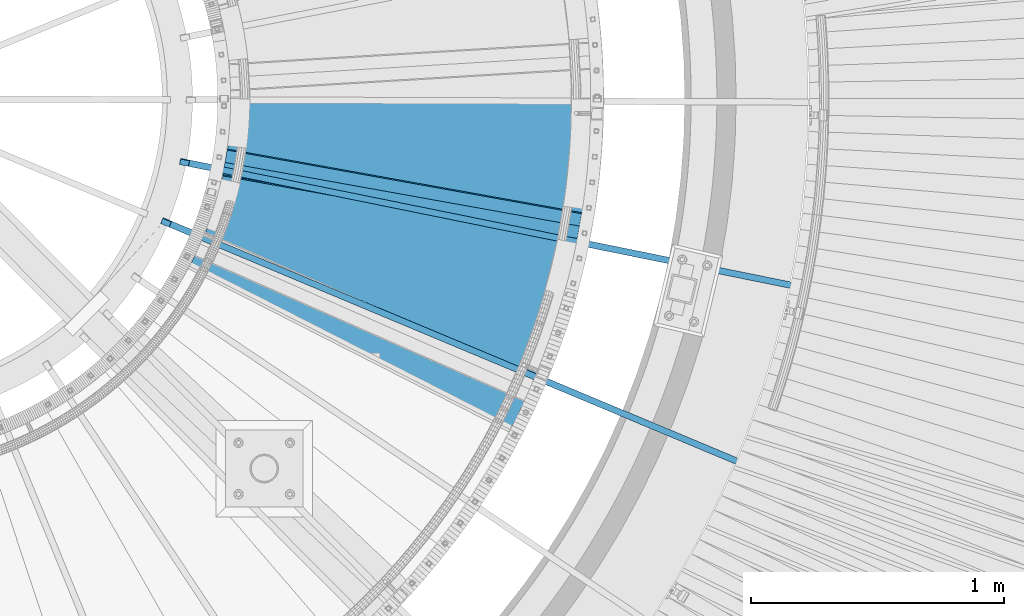
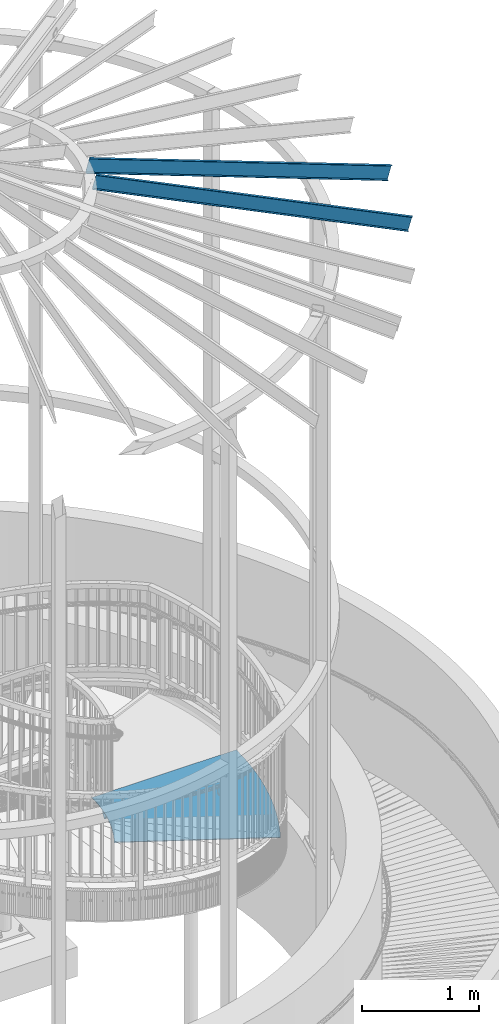
# One storey, part 360 of 975: 4 beams.
"""IFC2X3 building model written with IfcOpenShell, lengths in millimetres."""

from ifc_helpers import new_model, si_unit, frame, origin_with_axes, place, context, subcontext, project, spatial, faceted_brep, material, type_object, element, save


model = new_model("IFC2X3")

# Units and contexts
model_context = context("Model", 3, precision=1e-05, world=origin_with_axes())
body_context = subcontext(model_context, "Body", "Model", "MODEL_VIEW")
ifc_project = project(units=[si_unit("LENGTHUNIT", "METRE", prefix="MILLI"), si_unit("AREAUNIT", "SQUARE_METRE"), si_unit("VOLUMEUNIT", "CUBIC_METRE"), si_unit("MASSUNIT", "GRAM", prefix="KILO"), si_unit("TIMEUNIT", "SECOND"), si_unit("PLANEANGLEUNIT", "RADIAN"), si_unit("SOLIDANGLEUNIT", "STERADIAN"), si_unit("THERMODYNAMICTEMPERATUREUNIT", "DEGREE_CELSIUS"), si_unit("LUMINOUSINTENSITYUNIT", "LUMEN")], contexts=[model_context])

# Site, building, storey
site_placement = place(None, origin_with_axes())
site = spatial("IfcSite", under=ifc_project, at=site_placement, CompositionType="ELEMENT")
building_placement = place(site_placement, origin_with_axes())
building = spatial("IfcBuilding", under=site, at=building_placement, Name="Undefined", CompositionType="ELEMENT")
storey_placement = place(building_placement, origin_with_axes())
storey = spatial("IfcBuildingStorey", under=building, at=storey_placement, Name="Undefined", CompositionType="ELEMENT", Elevation=0.0)

# Beams
ifc_material_1 = material(Name="STEEL/A36")
beam_type_1 = type_object("IfcBeamType", Name="L3X3X1/4", PredefinedType="NOTDEFINED")
beam_1_placement = place(storey_placement, frame((36134.359374558, 3151.98091969875, 2078.30987194315), z_axis=(0.12494605674273, 0.695980231873518, 0.707106781006749), x_axis=(0.984264682808828, -0.17670040796568, 0.0)))
element("IfcBeam", 1, at=beam_1_placement, inside=storey, type_object=beam_type_1, material=ifc_material_1, Name="ANGLE", ObjectType="L3X3X1/4", context=body_context, shape_type="Brep", body=[
    faceted_brep([(-6.18456397205591e-11, 38.0999999999876, -38.1000000000258), (1.45519152283669e-10, 38.1000000000295, 38.1000000000386), (1423.28392836863, 38.0999999996639, 38.0999999996748), (1423.28392836842, 38.0999999996202, -38.1000000003896), (1.41881173476577e-10, 31.7500000000291, 38.1000000000404), (1423.28392836862, 31.7499999996635, 38.0999999996766), (-5.45696821063757e-11, 31.7499999999909, -31.75000000002), (1423.28392836843, 31.7499999996235, -31.7500000003856), (-1.23691279441118e-10, -38.100000000024, -31.7500000000309), (1423.28392836836, -38.1000000003878, -31.7500000003965), (-1.41881173476577e-10, -38.1000000000258, -38.1000000000386), (1423.28392836833, -38.1000000003933, -38.100000000406)], [[[0, 1, 2, 3]], [[1, 4, 5, 2]], [[4, 6, 7, 5]], [[6, 8, 9, 7]], [[8, 10, 11, 9]], [[10, 0, 3, 11]], [[5, 7, 9, 11, 3, 2]], [[10, 8, 6, 4, 1, 0]]]),
])
beam_type_2 = type_object("IfcBeamType", PredefinedType="NOTDEFINED")
beam_2_placement = place(storey_placement, frame((36868.1183427357, 3398.49214906007, 2085.975), z_axis=(-0.96771347667968, 0.252052825916566, 0.0), x_axis=(-0.252052825916566, -0.96771347667968, 0.0)))
element("IfcBeam", 2, at=beam_2_placement, inside=storey, type_object=beam_type_2, material=ifc_material_1, Name="TREAD", context=body_context, shape_type="Brep", body=[
    faceted_brep([(848.456586314382, 3.17500000000018, 678.083402893979), (848.456586314382, -3.17500000000018, 678.083402893979), (860.099577178291, -3.17500000000018, 680.92993623254), (860.099577178291, 3.17500000000018, 680.92993623254), (836.788775469362, 3.17500000000018, 675.340379308676), (836.788775469362, -3.17500000000018, 675.340379308676), (825.097064857448, 3.17500000000018, 672.701081812804), (825.097064857448, -3.17500000000018, 672.701081812804), (813.38237657776, 3.17500000000018, 670.165718561831), (813.38237657776, -3.17500000000018, 670.165718561831), (801.645634541632, 3.17500000000018, 667.734489514231), (801.645634541632, -3.17500000000018, 667.734489514231), (789.887764399717, 3.17500000000018, 665.407586415589), (789.887764399717, -3.17500000000018, 665.407586415589), (778.109693469001, 3.17500000000018, 663.185192783581), (778.109693469001, -3.17500000000018, 663.185192783581), (766.312350659662, 3.17500000000018, 661.067483893421), (766.312350659662, -3.17500000000018, 661.067483893421), (754.496666401803, 3.17500000000018, 659.054626764089), (754.496666401803, -3.17500000000018, 659.054626764089), (742.663572572077, 3.17500000000018, 657.146780145136), (742.663572572077, -3.17500000000018, 657.146780145136), (730.814002420193, 3.17500000000018, 655.344094504173), (730.814002420193, -3.17500000000018, 655.344094504173), (718.948890495318, 3.17500000000018, 653.64671201499), (718.948890495318, -3.17500000000018, 653.64671201499), (707.069172572343, 3.17500000000018, 652.054766546353), (707.069172572343, -3.17500000000018, 652.054766546353), (695.175785578125, 3.17500000000018, 650.568383651451), (695.175785578125, -3.17500000000018, 650.568383651451), (683.269667517558, 3.17500000000018, 649.187680557996), (683.269667517558, -3.17500000000018, 649.187680557996), (671.351757399607, 3.17500000000018, 647.912766158952), (671.351757399607, -3.17500000000018, 647.912766158952), (659.422995163253, 3.17500000000018, 646.743741003964), (659.422995163253, -3.17500000000018, 646.743741003964), (647.484321603357, 3.17500000000018, 645.680697291449), (647.484321603357, -3.17500000000018, 645.680697291449), (635.536678296467, 3.17500000000018, 644.7237188613), (635.536678296467, -3.17500000000018, 644.7237188613), (623.581007526554, 3.17500000000018, 643.872881188254), (623.581007526554, -3.17500000000018, 643.872881188254), (611.618252210696, 3.17500000000018, 643.128251375994), (611.618252210696, -3.17500000000018, 643.128251375994), (599.649355824713, 3.17500000000018, 642.489888151795), (599.649355824713, -3.17500000000018, 642.489888151795), (587.675262328758, 3.17500000000018, 641.957841861957), (587.675262328758, -3.17500000000018, 641.957841861957), (575.696916092867, 3.17500000000018, 641.532154467772), (575.696916092867, -3.17500000000018, 641.532154467772), (563.715261822486, 3.17500000000018, 641.212859542262), (563.715261822486, -3.17500000000018, 641.212859542262), (551.731244483954, 3.17500000000018, 640.999982267516), (551.731244483954, -3.17500000000018, 640.999982267516), (539.745809229977, 3.17500000000018, 640.893539432669), (539.745809229977, -3.17500000000018, 640.893539432669), (527.759901325095, 3.17500000000018, 640.89353943264), (527.759901325095, -3.17500000000018, 640.89353943264), (515.774466071114, 3.17500000000018, 640.999982267422), (515.774466071114, -3.17500000000018, 640.999982267422), (503.790448732583, 3.17500000000018, 641.212859542116), (503.790448732583, -3.17500000000018, 641.212859542116), (491.808794462204, 3.17500000000018, 641.532154467561), (491.808794462204, -3.17500000000018, 641.532154467561), (479.830448226316, 3.17500000000018, 641.95784186168), (479.830448226316, -3.17500000000018, 641.95784186168), (467.856354730362, 3.17500000000018, 642.48988815146), (467.856354730362, -3.17500000000018, 642.48988815146), (455.887458344378, 3.17500000000018, 643.128251375594), (455.887458344378, -3.17500000000018, 643.128251375594), (443.924703028522, 3.17500000000018, 643.872881187795), (443.924703028522, -3.17500000000018, 643.872881187795), (431.96903225861, 3.17500000000018, 644.723718860776), (431.96903225861, -3.17500000000018, 644.723718860776), (420.021388951722, 3.17500000000018, 645.680697290867), (420.021388951722, -3.17500000000018, 645.680697290867), (408.082715391829, 3.17500000000018, 646.743741003324), (408.082715391829, -3.17500000000018, 646.743741003324), (396.153953155475, 3.17500000000018, 647.912766158239), (396.153953155475, -3.17500000000018, 647.912766158239), (384.236043037527, 3.17500000000018, 649.187680557232), (384.236043037527, -3.17500000000018, 649.187680557232), (372.329924976961, 3.17500000000018, 650.568383650629), (372.329924976961, -3.17500000000018, 650.568383650629), (360.436537982743, 3.17500000000018, 652.054766545465), (360.436537982743, -3.17500000000018, 652.054766545465), (348.556820059774, 3.17500000000018, 653.646712014044), (348.556820059774, -3.17500000000018, 653.646712014044), (336.691708134898, 3.17500000000018, 655.344094503169), (336.691708134898, -3.17500000000018, 655.344094503169), (324.842137983018, 3.17500000000018, 657.146780144074), (324.842137983018, -3.17500000000018, 657.146780144074), (313.009044153298, 3.17500000000018, 659.054626762969), (313.009044153298, -3.17500000000018, 659.054626762969), (301.193359895438, 3.17500000000018, 661.067483892235), (301.193359895438, -3.17500000000018, 661.067483892235), (289.396017086103, 3.17500000000018, 663.18519278233), (289.396017086103, -3.17500000000018, 663.18519278233), (277.617946155391, 3.17500000000018, 665.407586414287), (277.617946155391, -3.17500000000018, 665.407586414287), (265.860076013483, 3.17500000000018, 667.734489512855), (265.860076013483, -3.17500000000018, 667.734489512855), (254.123333977357, 3.17500000000018, 670.165718560413), (254.123333977357, -3.17500000000018, 670.165718560413), (242.408645697673, 3.17500000000018, 672.701081811319), (242.408645697673, -3.17500000000018, 672.701081811319), (230.716935085762, 3.17500000000018, 675.340379307141), (230.716935085762, -3.17500000000018, 675.340379307141), (219.049124240748, 3.17500000000018, 678.083402892378), (219.049124240748, -3.17500000000018, 678.083402892378), (207.40613337684, 3.17500000000018, 680.929936230874), (207.40613337684, -3.17500000000018, 680.929936230874), (195.788880750757, 3.17500000000018, 683.879754822912), (195.788880750757, -3.17500000000018, 683.879754822912), (184.198282589285, 3.17500000000018, 686.932626022855), (184.198282589285, -3.17500000000018, 686.932626022855), (174.342338310295, 3.17500000000018, 689.622425954447), (174.342338310295, -3.17500000000018, 689.622425954447), (-184.198282589288, 3.17500000000018, -686.932626022863), (-184.198282589288, -3.17500000000018, -686.932626022863), (-160.392319833383, 3.17500000000018, -693.202926922961), (-160.392319833383, -3.17500000000018, -693.202926922961), (-136.531611396278, 3.17500000000018, -699.261567776535), (-136.531611396278, -3.17500000000018, -699.261567776535), (-112.618039118806, 3.17500000000018, -705.108070752111), (-112.618039118806, -3.17500000000018, -705.108070752111), (-88.6534890110615, 3.17500000000018, -710.741974749049), (-88.6534890110615, -3.17500000000018, -710.741974749049), (-64.6398511036386, 3.17500000000018, -716.16283543389), (-64.6398511036386, -3.17500000000018, -716.16283543389), (-40.5790192985842, 3.17500000000018, -721.370225275467), (-40.5790192985842, -3.17500000000018, -721.370225275467), (-16.4728912200117, 3.17500000000018, -726.363733578546), (-16.4728912200117, -3.17500000000018, -726.363733578546), (7.67663193553199, 3.17500000000018, -731.14296651628), (7.67663193553199, -3.17500000000018, -731.14296651628), (31.8676455490458, 3.17500000000018, -735.707547161219), (31.8676455490458, -3.17500000000018, -735.707547161219), (56.098241729258, 3.17500000000018, -740.05711551509), (56.098241729258, -3.17500000000018, -740.05711551509), (80.3665094631087, 3.17500000000018, -744.191328537119), (80.3665094631087, -3.17500000000018, -744.191328537119), (104.67053476647, 3.17500000000018, -748.109860171171), (104.67053476647, -3.17500000000018, -748.109860171171), (129.008400835093, 3.17500000000018, -751.81240137139), (129.008400835093, -3.17500000000018, -751.81240137139), (153.378188195782, 3.17500000000018, -755.298660126602), (153.378188195782, -3.17500000000018, -755.298660126602), (177.777974857781, 3.17500000000018, -758.568361483369), (177.777974857781, -3.17500000000018, -758.568361483369), (202.205836464358, 3.17500000000018, -761.621247567637), (202.205836464358, -3.17500000000018, -761.621247567637), (226.659846444571, 3.17500000000018, -764.457077605097), (226.659846444571, -3.17500000000018, -764.457077605097), (251.138076165209, 3.17500000000018, -767.075627940161), (251.138076165209, -3.17500000000018, -767.075627940161), (275.638595082914, 3.17500000000018, -769.476692053606), (275.638595082914, -3.17500000000018, -769.476692053606), (300.159470896422, 3.17500000000018, -771.660080578855), (300.159470896422, -3.17500000000018, -771.660080578855), (324.698769698971, 3.17500000000018, -773.625621316918), (324.698769698971, -3.17500000000018, -773.625621316918), (349.254556130811, 3.17500000000018, -775.373159250012), (349.254556130811, -3.17500000000018, -775.373159250012), (373.824893531859, 3.17500000000018, -776.902556553694), (373.824893531859, -3.17500000000018, -776.902556553694), (398.407844094421, 3.17500000000018, -778.213692607824), (398.407844094421, -3.17500000000018, -778.213692607824), (423.001469016037, 3.17500000000018, -779.306464006026), (423.001469016037, -3.17500000000018, -779.306464006026), (447.603828652384, 3.17500000000018, -780.180784563847), (447.603828652384, -3.17500000000018, -780.180784563847), (472.212982670244, 3.17500000000018, -780.836585325589), (472.212982670244, -3.17500000000018, -780.836585325589), (496.826990200552, 3.17500000000018, -781.2738145697), (496.826990200552, -3.17500000000018, -781.2738145697), (521.443909991451, 3.17500000000018, -781.492437812893), (521.443909991451, -3.17500000000018, -781.492437812893), (546.061800561401, 3.17500000000018, -781.492437812827), (546.061800561401, -3.17500000000018, -781.492437812827), (570.678720352302, 3.17500000000018, -781.273814569504), (570.678720352302, -3.17500000000018, -781.273814569504), (595.29272788261, 3.17500000000018, -780.836585325269), (595.29272788261, -3.17500000000018, -780.836585325269), (619.901881900474, 3.17500000000018, -780.18078456341), (619.901881900474, -3.17500000000018, -780.18078456341), (644.504241536819, 3.17500000000018, -779.306464005465), (644.504241536819, -3.17500000000018, -779.306464005465), (669.09786645844, 3.17500000000018, -778.21369260714), (669.09786645844, -3.17500000000018, -778.21369260714), (693.680817021004, 3.17500000000018, -776.902556552886), (693.680817021004, -3.17500000000018, -776.902556552886), (718.251154422052, 3.17500000000018, -775.373159249073), (718.251154422052, -3.17500000000018, -775.373159249073), (742.806940853898, 3.17500000000018, -773.625621315863), (742.806940853898, -3.17500000000018, -773.625621315863), (767.346239656446, 3.17500000000018, -771.660080577662), (767.346239656446, -3.17500000000018, -771.660080577662), (791.867115469959, 3.17500000000018, -769.476692052289), (791.867115469959, -3.17500000000018, -769.476692052289), (816.367634387667, 3.17500000000018, -767.075627938728), (816.367634387667, -3.17500000000018, -767.075627938728), (840.845864108313, 3.17500000000018, -764.45707760354), (840.845864108313, -3.17500000000018, -764.45707760354), (865.299874088527, 3.17500000000018, -761.621247565956), (865.299874088527, -3.17500000000018, -761.621247565956), (889.727735695109, 3.17500000000018, -758.568361481557), (889.727735695109, -3.17500000000018, -758.568361481557), (914.127522357112, 3.17500000000018, -755.298660124667), (914.127522357112, -3.17500000000018, -755.298660124667), (938.497309717808, 3.17500000000018, -751.812401369323), (938.497309717808, -3.17500000000018, -751.812401369323), (962.835175786435, 3.17500000000018, -748.109860168981), (962.835175786435, -3.17500000000018, -748.109860168981), (987.139201089803, 3.17500000000018, -744.191328534813), (987.139201089803, -3.17500000000018, -744.191328534813), (1011.40746882366, 3.17500000000018, -740.057115512653), (1011.40746882366, -3.17500000000018, -740.057115512653), (1035.63806500388, 3.17500000000018, -735.707547158665), (1035.63806500388, -3.17500000000018, -735.707547158665), (1059.8290786174, 3.17500000000018, -731.142966513595), (1059.8290786174, -3.17500000000018, -731.142966513595), (1083.97860177295, 3.17500000000018, -726.363733575738), (1083.97860177295, -3.17500000000018, -726.363733575738), (1108.08472985153, 3.17500000000018, -721.370225272534), (1108.08472985153, -3.17500000000018, -721.370225272534), (1132.14556165659, 3.17500000000018, -716.162835430834), (1132.14556165659, -3.17500000000018, -716.162835430834), (1156.15919956402, 3.17500000000018, -710.74197474587), (1156.15919956402, -3.17500000000018, -710.74197474587), (1171.1640058451, -3.17500000000018, -707.214446054459), (865.970327157656, -3.17500000000018, 682.420619787074), (865.970327157656, 3.17500000000018, 682.420619787074), (1171.1640058451, 3.17500000000018, -707.214446054459)], [[[0, 1, 2, 3]], [[4, 5, 1, 0]], [[6, 7, 5, 4]], [[8, 9, 7, 6]], [[10, 11, 9, 8]], [[12, 13, 11, 10]], [[14, 15, 13, 12]], [[16, 17, 15, 14]], [[18, 19, 17, 16]], [[20, 21, 19, 18]], [[22, 23, 21, 20]], [[24, 25, 23, 22]], [[26, 27, 25, 24]], [[28, 29, 27, 26]], [[30, 31, 29, 28]], [[32, 33, 31, 30]], [[34, 35, 33, 32]], [[36, 37, 35, 34]], [[38, 39, 37, 36]], [[40, 41, 39, 38]], [[42, 43, 41, 40]], [[44, 45, 43, 42]], [[46, 47, 45, 44]], [[48, 49, 47, 46]], [[50, 51, 49, 48]], [[52, 53, 51, 50]], [[54, 55, 53, 52]], [[56, 57, 55, 54]], [[58, 59, 57, 56]], [[60, 61, 59, 58]], [[62, 63, 61, 60]], [[64, 65, 63, 62]], [[66, 67, 65, 64]], [[68, 69, 67, 66]], [[70, 71, 69, 68]], [[72, 73, 71, 70]], [[74, 75, 73, 72]], [[76, 77, 75, 74]], [[78, 79, 77, 76]], [[80, 81, 79, 78]], [[82, 83, 81, 80]], [[84, 85, 83, 82]], [[86, 87, 85, 84]], [[88, 89, 87, 86]], [[90, 91, 89, 88]], [[92, 93, 91, 90]], [[94, 95, 93, 92]], [[96, 97, 95, 94]], [[98, 99, 97, 96]], [[100, 101, 99, 98]], [[102, 103, 101, 100]], [[104, 105, 103, 102]], [[106, 107, 105, 104]], [[108, 109, 107, 106]], [[110, 111, 109, 108]], [[112, 113, 111, 110]], [[114, 115, 113, 112]], [[115, 114, 116, 117]], [[118, 119, 117, 116]], [[120, 121, 119, 118]], [[121, 120, 122, 123]], [[123, 122, 124, 125]], [[125, 124, 126, 127]], [[127, 126, 128, 129]], [[129, 128, 130, 131]], [[131, 130, 132, 133]], [[133, 132, 134, 135]], [[135, 134, 136, 137]], [[137, 136, 138, 139]], [[139, 138, 140, 141]], [[141, 140, 142, 143]], [[143, 142, 144, 145]], [[145, 144, 146, 147]], [[147, 146, 148, 149]], [[149, 148, 150, 151]], [[151, 150, 152, 153]], [[153, 152, 154, 155]], [[155, 154, 156, 157]], [[157, 156, 158, 159]], [[159, 158, 160, 161]], [[161, 160, 162, 163]], [[163, 162, 164, 165]], [[165, 164, 166, 167]], [[167, 166, 168, 169]], [[169, 168, 170, 171]], [[171, 170, 172, 173]], [[173, 172, 174, 175]], [[175, 174, 176, 177]], [[177, 176, 178, 179]], [[179, 178, 180, 181]], [[181, 180, 182, 183]], [[183, 182, 184, 185]], [[185, 184, 186, 187]], [[187, 186, 188, 189]], [[189, 188, 190, 191]], [[191, 190, 192, 193]], [[193, 192, 194, 195]], [[195, 194, 196, 197]], [[197, 196, 198, 199]], [[199, 198, 200, 201]], [[201, 200, 202, 203]], [[203, 202, 204, 205]], [[205, 204, 206, 207]], [[207, 206, 208, 209]], [[209, 208, 210, 211]], [[211, 210, 212, 213]], [[213, 212, 214, 215]], [[215, 214, 216, 217]], [[217, 216, 218, 219]], [[219, 218, 220, 221]], [[221, 220, 222, 223]], [[223, 222, 224, 225]], [[225, 224, 226, 227]], [[227, 226, 228, 229]], [[2, 1, 5, 7, 9, 11, 13, 15, 17, 19, 21, 23, 25, 27, 29, 31, 33, 35, 37, 39, 41, 43, 45, 47, 49, 51, 53, 55, 57, 59, 61, 63, 65, 67, 69, 71, 73, 75, 77, 79, 81, 83, 85, 87, 89, 91, 93, 95, 97, 99, 101, 103, 105, 107, 109, 111, 113, 115, 117, 119, 121, 123, 125, 127, 129, 131, 133, 135, 137, 139, 141, 143, 145, 147, 149, 151, 153, 155, 157, 159, 161, 163, 165, 167, 169, 171, 173, 175, 177, 179, 181, 183, 185, 187, 189, 191, 193, 195, 197, 199, 201, 203, 205, 207, 209, 211, 213, 215, 217, 219, 221, 223, 225, 227, 229, 230, 231]], [[3, 2, 231, 232]], [[228, 226, 224, 222, 220, 218, 216, 214, 212, 210, 208, 206, 204, 202, 200, 198, 196, 194, 192, 190, 188, 186, 184, 182, 180, 178, 176, 174, 172, 170, 168, 166, 164, 162, 160, 158, 156, 154, 152, 150, 148, 146, 144, 142, 140, 138, 136, 134, 132, 130, 128, 126, 124, 122, 120, 118, 116, 114, 112, 110, 108, 106, 104, 102, 100, 98, 96, 94, 92, 90, 88, 86, 84, 82, 80, 78, 76, 74, 72, 70, 68, 66, 64, 62, 60, 58, 56, 54, 52, 50, 48, 46, 44, 42, 40, 38, 36, 34, 32, 30, 28, 26, 24, 22, 20, 18, 16, 14, 12, 10, 8, 6, 4, 0, 3, 232, 233]], [[229, 228, 233, 230]], [[232, 231, 230, 233]]]),
])
ifc_material_2 = material(Name="STEEL/Zero_Density")
beam_type_3 = type_object("IfcBeamType", PredefinedType="NOTDEFINED")
for number, where, z_axis, x_axis, name in (
    (3, (35902.1290859171, 2915.30822426357, 8885.0313138005), (0.223737955733079, -0.0936371633068038, 0.970140922140819), (0.894927076878677, -0.374538296949224, -0.242541936967119), "STUD"),
    (4, (35974.9544202045, 3152.48374818272, 8885.0313138005), (0.237706597905657, -0.0481888419808747, 0.97014092214516), (0.950800100803031, -0.19275003796007, -0.242541936949755), "STUD"),
):
    element("IfcBeam", number, at=place(storey_placement, frame(where, z_axis=z_axis, x_axis=x_axis)), inside=storey, type_object=beam_type_3, material=ifc_material_2, Name=name, context=body_context, shape_type="Brep", body=[
        faceted_brep([(-1.67347025126219e-10, 12.6999999998588, -76.2000000000985), (1.96450855582952e-10, 12.7000000001644, 76.2000000001021), (2798.98467503002, 12.7000000041553, 76.2000000028588), (2798.98467502966, 12.7000000038533, -76.1999999973427), (1.74622982740402e-10, -12.6999999998661, 76.2000000000985), (2798.98467503, -12.6999999958753, 76.2000000028534), (1.67347025126219e-10, -12.6999999998698, 73.0250000000947), (2798.98467502999, -12.6999999958789, 73.0250000028504), (1.89174897968769e-10, 9.52500000015425, 73.0250000000974), (2798.98467503001, 9.52500000414511, 73.0250000028532), (-1.60071067512035e-10, 9.52499999986321, -73.0250000000938), (2798.98467502966, 9.52500000385407, -73.0249999973398), (-1.81898940354586e-10, -12.7000000001608, -73.0250000000965), (2798.98467502964, -12.6999999961699, -73.0249999973416), (-1.92812876775861e-10, -12.7000000001717, -76.2000000001003), (2798.98467502963, -12.6999999961772, -76.1999999973455)], [[[0, 1, 2, 3]], [[1, 4, 5, 2]], [[4, 6, 7, 5]], [[6, 8, 9, 7]], [[8, 10, 11, 9]], [[10, 12, 13, 11]], [[12, 14, 15, 13]], [[14, 0, 3, 15]], [[5, 7, 9, 11, 13, 15, 3, 2]], [[14, 12, 10, 8, 6, 4, 1, 0]]]),
    ])

save(model, "model.ifc")
